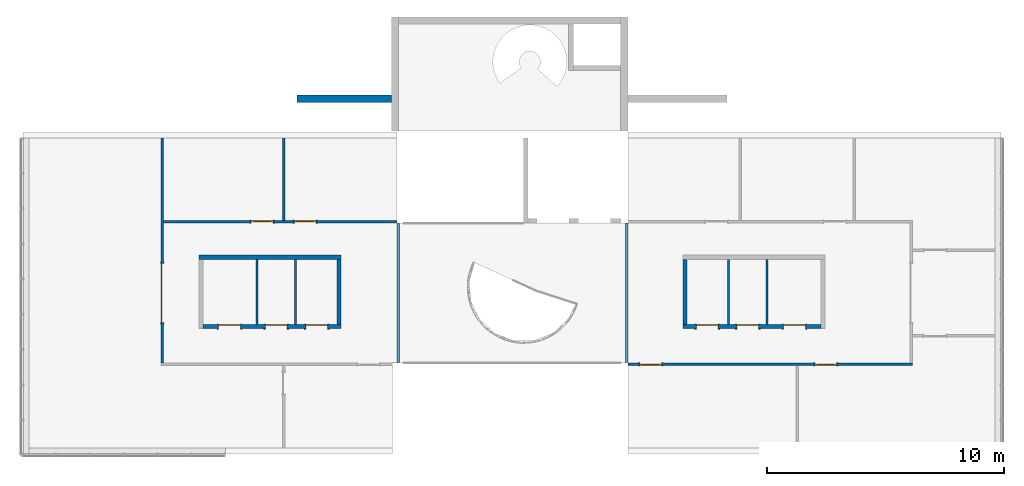
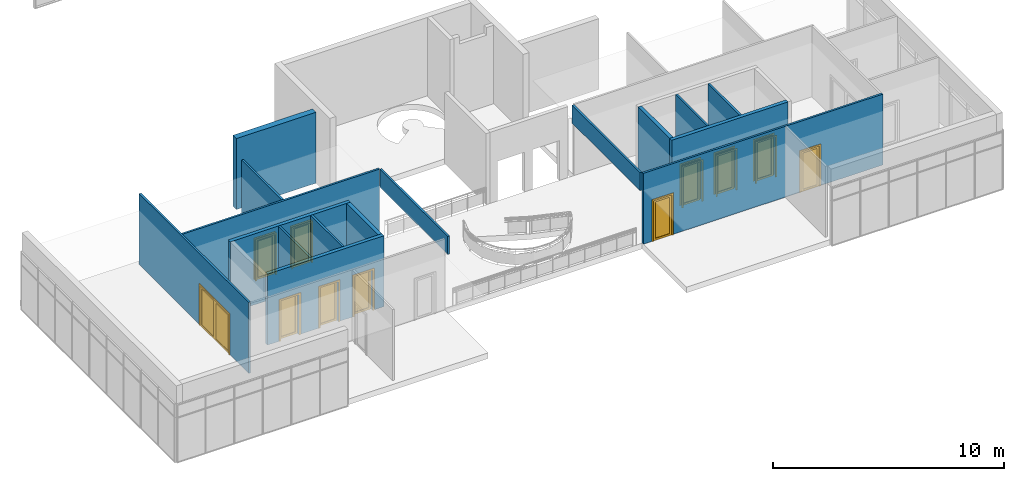
# One storey, part 8 of 11: 16 walls, 11 doors, 11 openings.
"""IFC2X3 building model written with IfcOpenShell, lengths in millimetres."""

from ifc_helpers import new_model, entity, si_unit, converted_unit, direction, frame, frame_2d, origin, origin_2d_with_axis, place, context, subcontext, project, spatial, polyline, rectangle, outline, extrude, source, transform, mapped, material, material_list, layer, layer_set, layer_usage, type_object, type_shapes, element, fill, save


model = new_model("IFC2X3")

# Units and contexts
model_context = context("Model", 3, precision=1e-06, world=origin(), true_north=direction((2.0, 6.12303176911189e-17, 1.0)))
context_of_model = context(None, 3, precision=1e-06, world=origin(), true_north=direction((2.0, 6.12303176911189e-17, 1.0)))
body_context = subcontext(model_context, "Body", "Model", "MODEL_VIEW")
ifc_project = project(units=[si_unit("LENGTHUNIT", "METRE", prefix="MILLI"), si_unit("AREAUNIT", "SQUARE_METRE", prefix="MILLI"), si_unit("VOLUMEUNIT", "CUBIC_METRE", prefix="MILLI"), converted_unit("PLANEANGLEUNIT", "DEGREE", entity("IfcRatioMeasure", 0.0174532925199433), si_unit("PLANEANGLEUNIT", "RADIAN"), dimensions=[0, 0, 0, 0, 0, 0, 0]), si_unit("TIMEUNIT", "SECOND")], contexts=[model_context, context_of_model])

# Site, building, storey
site_placement = place(None, origin())
site = spatial("IfcSite", under=ifc_project, at=site_placement, CompositionType="ELEMENT")
building_placement = place(site_placement, origin())
building = spatial("IfcBuilding", under=site, at=building_placement, CompositionType="ELEMENT")
storey_placement = place(building_placement, frame((0.0, 0.0, 3750.0)))
storey = spatial("IfcBuildingStorey", under=building, at=storey_placement, Name="02. 2 etg.", CompositionType="ELEMENT", Elevation=3750.00000000068)

# Wall, opening, door
ifc_material_1 = material(Name="Steel, Paint Finish, Ivory, Matte")
ifc_layer_1 = layer(ifc_material_1, 100.0)
ifc_layer_set_1 = layer_set([ifc_layer_1], Name="Basic Wall:_100mm")
ifc_layer_usage_1 = layer_usage(ifc_layer_set_1, "AXIS2", "NEGATIVE", 50.0)
wall_1_placement = place(storey_placement, frame((5679.11785617473, -9550.0, 0.0), z_axis=(0.0, 0.0, 1.0), x_axis=(0.0, 1.0, 0.0)))
wall_1 = element("IfcWallStandardCase", 1, at=wall_1_placement, inside=storey, material=ifc_layer_usage_1, Name="Basic Wall:_100mm", ObjectType="Basic Wall:_100mm", context=body_context, shape_type="SweptSolid", body=[
    extrude(rectangle(XDim=9490.00000000001, YDim=100.000000000001, at=frame_2d((4745.00000000001, 0.0), x_axis=(-1.0, 0.0))), origin(), (0.0, 0.0, 1.0), 3750.0),
])
opening_1_placement = place(wall_1_placement, frame((1700.0, -50.0, 0.0)))
opening_1 = element("IfcOpeningElement", 2, at=opening_1_placement, cuts=wall_1, Name="M_Double-Glass 1:2500x2100:2500x2100:1", ObjectType="Opening", context=body_context, shape_type="SweptSolid", body=[
    extrude(rectangle(XDim=2500.0, YDim=2100.0, at=frame_2d((1050.0, 1250.0), x_axis=(0.0, 1.0))), frame((0.0, 0.0, 0.0), z_axis=(0.0, 1.0, 0.0), x_axis=(0.0, 0.0, 1.0)), (0.0, 0.0, 1.0), 100.0),
])
ifc_material_2 = material(Name="Metal - Stainless Steel,Polished")
ifc_material_3 = material(Name="Glass")
ifc_material_4 = material(Name="Steel, Chrome Plated")
ifc_material_list_1 = material_list([ifc_material_2, ifc_material_3, ifc_material_4])
door_style_1 = type_object("IfcDoorStyle", Name="2500x2100", ConstructionType="NOTDEFINED", OperationType="DOUBLE_DOOR_SINGLE_SWING", ParameterTakesPrecedence=False, Sizeable=False)
shared_shape_1 = source(origin(), body_context, "Body", "SweptSolid", [
    extrude(outline(polyline([(-1326.0, -1069.0), (-1250.0, -1069.0), (-1250.0, 1031.0), (1250.0, 1031.0), (1250.0, -1069.0), (1326.0, -1069.0), (1326.0, 1107.0), (-1326.0, 1107.0), (-1326.0, -1069.0)])), frame((1250.0, -25.0, 1069.0), z_axis=(0.0, 1.0, 0.0), x_axis=(-1.0, 0.0, 0.0)), (0.0, 0.0, 1.0), 25.0),
    extrude(outline(polyline([(-1250.0, -1031.0), (-1250.0, 1069.0), (-1326.0, 1069.0), (-1326.0, -1107.0), (1326.0, -1107.0), (1326.0, 1069.0), (1250.0, 1069.0), (1250.0, -1031.0), (-1250.0, -1031.0)])), frame((1250.0, 100.0, 1069.0), z_axis=(0.0, -1.0, 0.0), x_axis=(-1.0, 0.0, 0.0)), (0.0, 0.0, -1.0), 24.999999999997),
    extrude(rectangle(XDim=7.14374999999973, YDim=1046.8, at=frame_2d((0.0, -5.6843418860808e-14), x_axis=(1.0, 0.0))), frame((1875.0, 78.1718749999958, 102.0), z_axis=(0.0, 0.0, 1.0), x_axis=(0.0, 1.0, 0.0)), (0.0, 0.0, 1.0), 1896.0),
    extrude(rectangle(XDim=7.14374999999973, YDim=1046.8, at=frame_2d((0.0, -5.6843418860808e-14), x_axis=(1.0, 0.0))), frame((625.0, 78.1718749999958, 102.0), z_axis=(0.0, 0.0, 1.0), x_axis=(0.0, 1.0, 0.0)), (0.0, 0.0, 1.0), 1896.0),
    extrude(outline(polyline([(-1050.0, -1250.0), (1050.0, -1250.0), (1050.0, 1250.0), (-1050.0, 1250.0), (-1050.0, -1250.0)]), holes=[polyline([(-948.0, 101.600000000038), (-948.0, 1148.40000000004), (948.0, 1148.40000000004), (948.0, 101.600000000038), (-948.0, 101.600000000038)]), polyline([(-948.0, -1148.39999999996), (-948.0, -101.599999999961), (948.0, -101.599999999961), (948.0, -1148.39999999996), (-948.0, -1148.39999999996)])]), frame((1250.0, 49.0, 1050.0), z_axis=(0.0, 1.0, 0.0), x_axis=(0.0, 0.0, -1.0)), (0.0, 0.0, 1.0), 51.0),
])
type_shapes(door_style_1, [shared_shape_1])
door_1_placement = place(opening_1_placement, origin())
door_1 = element("IfcDoor", 3, at=door_1_placement, inside=storey, type_object=door_style_1, material=ifc_material_list_1, Name="M_Double-Glass 1:2500x2100:2500x2100", ObjectType="2500x2100", OverallHeight=2100.0, OverallWidth=2500.0, context=body_context, shape_type="MappedRepresentation", body=[
    mapped(shared_shape_1, transform((0.0, 0.0, 0.0), scale=1.0)),
])
fill(opening_1, door_1)

# Wall, openings, doors
ifc_layer_usage_2 = layer_usage(ifc_layer_set_1, "AXIS2", "NEGATIVE", 50.0)
wall_2_placement = place(storey_placement, frame((15590.0, -3600.0, 0.0), z_axis=(0.0, 0.0, 1.0), x_axis=(-1.0, 0.0, 0.0)))
wall_2 = element("IfcWallStandardCase", 4, at=wall_2_placement, inside=storey, material=ifc_layer_usage_2, Name="Basic Wall:_100mm", ObjectType="Basic Wall:_100mm", context=body_context, shape_type="SweptSolid", body=[
    extrude(rectangle(XDim=9860.88214382529, YDim=100.0, at=frame_2d((4930.44107191265, 3.5527136788005e-14), x_axis=(-1.0, 0.0))), origin(), (0.0, 0.0, 1.0), 3750.0),
])
opening_2_placement = place(wall_2_placement, frame((6155.0, 50.0, 0.0)))
opening_2 = element("IfcOpeningElement", 5, at=opening_2_placement, cuts=wall_2, Name="M_Single-Glass 1:0915 x 2134mm:0915 x 2134mm:1", ObjectType="Opening", context=body_context, shape_type="SweptSolid", body=[
    extrude(rectangle(XDim=914.999999999999, YDim=2134.0, at=frame_2d((1067.0, 457.5), x_axis=(0.0, 1.0))), frame((0.0, 0.0, 0.0), z_axis=(0.0, -1.0, 0.0), x_axis=(0.0, 0.0, 1.0)), (0.0, 0.0, 1.0), 100.0),
])
opening_3_placement = place(wall_2_placement, frame((4340.0, 50.0, 0.0)))
opening_3 = element("IfcOpeningElement", 6, at=opening_3_placement, cuts=wall_2, Name="M_Single-Glass 1:0915 x 2134mm:0915 x 2134mm:1", ObjectType="Opening", context=body_context, shape_type="SweptSolid", body=[
    extrude(rectangle(XDim=914.999999999999, YDim=2134.0, at=frame_2d((1067.0, 457.5), x_axis=(0.0, -1.0))), frame((0.0, 0.0, 0.0), z_axis=(0.0, -1.0, 0.0), x_axis=(0.0, 0.0, 1.0)), (0.0, 0.0, 1.0), 100.0),
])
ifc_material_5 = material(Name="Stainless Steel")
ifc_material_list_2 = material_list([ifc_material_5, ifc_material_3])
door_style_2 = type_object("IfcDoorStyle", Name="0915 x 2134mm", ConstructionType="NOTDEFINED", OperationType="SINGLE_SWING_RIGHT", ParameterTakesPrecedence=False, Sizeable=False)
shared_shape_2 = source(origin(), body_context, "Body", "SweptSolid", [
    extrude(outline(polyline([(-457.500000000003, -1048.0), (-457.500000000003, 1086.0), (-533.499999999999, 1086.0), (-533.499999999999, -1124.0), (533.500000000001, -1124.0), (533.500000000001, 1086.0), (457.500000000001, 1086.0), (457.500000000001, -1048.0), (-457.500000000003, -1048.0)])), frame((457.500000000001, -25.0, 1086.0), z_axis=(0.0, -1.0, 0.0), x_axis=(-1.0, 0.0, 0.0)), (0.0, 0.0, -1.0), 25.0),
    extrude(outline(polyline([(-457.500000000001, -1048.0), (-457.500000000001, 1086.0), (-533.499999999997, 1086.0), (-533.499999999997, -1124.0), (533.499999999999, -1124.0), (533.499999999999, 1086.0), (457.499999999999, 1086.0), (457.499999999999, -1048.0), (-457.500000000001, -1048.0)])), frame((457.499999999999, 100.0, 1086.0), z_axis=(0.0, -1.0, 0.0), x_axis=(-1.0, 0.0, 0.0)), (0.0, 0.0, -1.0), 25.0000000000156),
    extrude(rectangle(XDim=6.35, YDim=711.0, at=frame_2d((-4.21884749357559e-15, 0.0), x_axis=(1.0, 0.0))), frame((457.5, 74.6000000000039, 102.0), z_axis=(0.0, 0.0, 1.0), x_axis=(0.0, 1.0, 0.0)), (0.0, 0.0, 1.0), 1930.0),
    extrude(outline(polyline([(-1067.0, -457.499999999998), (1067.0, -457.499999999998), (1067.0, 457.499999999998), (-1067.0, 457.499999999998), (-1067.0, -457.499999999998)]), holes=[polyline([(-965.0, 355.499999999998), (965.0, 355.499999999998), (965.0, -355.500000000002), (-965.0, -355.500000000002), (-965.0, 355.499999999998)])]), frame((457.499999999998, 49.0, 1067.0), z_axis=(0.0, 1.0, 0.0), x_axis=(0.0, 0.0, -1.0)), (0.0, 0.0, 1.0), 51.0),
])
type_shapes(door_style_2, [shared_shape_2])
door_2_placement = place(opening_2_placement, frame((0.0, 0.0, 0.0), z_axis=(0.0, 0.0, 1.0), x_axis=(-1.0, 0.0, 0.0)))
door_2 = element("IfcDoor", 7, at=door_2_placement, inside=storey, type_object=door_style_2, material=ifc_material_list_2, Name="M_Single-Glass 1:0915 x 2134mm:0915 x 2134mm", ObjectType="0915 x 2134mm", OverallHeight=2134.0, OverallWidth=915.0, context=body_context, shape_type="MappedRepresentation", body=[
    mapped(shared_shape_2, transform((0.0, 0.0, 0.0), scale=1.0)),
])
fill(opening_2, door_2)
ifc_material_list_3 = material_list([ifc_material_5, ifc_material_3])
door_style_3 = type_object("IfcDoorStyle", Name="0915 x 2134mm", ConstructionType="NOTDEFINED", OperationType="SINGLE_SWING_LEFT", ParameterTakesPrecedence=False, Sizeable=False)
shared_shape_3 = source(origin(), body_context, "Body", "SweptSolid", [
    extrude(outline(polyline([(-457.500000000003, -1048.0), (-457.500000000003, 1086.0), (-533.499999999999, 1086.0), (-533.499999999999, -1124.0), (533.500000000001, -1124.0), (533.500000000001, 1086.0), (457.500000000001, 1086.0), (457.500000000001, -1048.0), (-457.500000000003, -1048.0)])), frame((457.499999999999, 0.0, 1086.0), z_axis=(0.0, 1.0, 0.0), x_axis=(1.0, 0.0, 0.0)), (0.0, 0.0, -1.0), 25.0),
    extrude(outline(polyline([(-457.500000000001, -1048.0), (-457.500000000001, 1086.0), (-533.499999999997, 1086.0), (-533.499999999997, -1124.0), (533.499999999999, -1124.0), (533.499999999999, 1086.0), (457.499999999999, 1086.0), (457.499999999999, -1048.0), (-457.500000000001, -1048.0)])), frame((457.500000000001, 125.0, 1086.0), z_axis=(0.0, 1.0, 0.0), x_axis=(1.0, 0.0, 0.0)), (0.0, 0.0, -1.0), 25.0000000000156),
    extrude(rectangle(XDim=711.0, YDim=6.35, at=origin_2d_with_axis()), frame((457.5, 74.6000000000257, 102.0)), (0.0, 0.0, 1.0), 1930.0),
    extrude(outline(polyline([(-1067.0, -457.499999999998), (1067.0, -457.499999999998), (1067.0, 457.499999999998), (-1067.0, 457.499999999998), (-1067.0, -457.499999999998)]), holes=[polyline([(-965.0, 355.499999999998), (965.0, 355.499999999998), (965.0, -355.500000000002), (-965.0, -355.500000000002), (-965.0, 355.499999999998)])]), frame((457.500000000002, 100.0, 1067.0), z_axis=(0.0, -1.0, 0.0), x_axis=(0.0, 0.0, -1.0)), (0.0, 0.0, 1.0), 51.0),
])
type_shapes(door_style_3, [shared_shape_3])
door_3_placement = place(opening_3_placement, frame((0.0, 0.0, 0.0), z_axis=(0.0, 0.0, 1.0), x_axis=(-1.0, 0.0, 0.0)))
door_3 = element("IfcDoor", 8, at=door_3_placement, inside=storey, type_object=door_style_3, material=ifc_material_list_3, Name="M_Single-Glass 1:0915 x 2134mm:0915 x 2134mm", ObjectType="0915 x 2134mm", OverallHeight=2134.0, OverallWidth=915.0, context=body_context, shape_type="MappedRepresentation", body=[
    mapped(shared_shape_3, transform((0.0, 0.0, 0.0), scale=1.0)),
])
fill(opening_3, door_3)

# Walls
ifc_layer_usage_3 = layer_usage(ifc_layer_set_1, "AXIS2", "NEGATIVE", 50.0)
wall_3_placement = place(storey_placement, frame((10800.0, -3550.0, 0.0), z_axis=(0.0, 0.0, 1.0), x_axis=(0.0, 1.0, 0.0)))
element("IfcWallStandardCase", 9, at=wall_3_placement, inside=storey, material=ifc_layer_usage_3, Name="Basic Wall:_100mm", ObjectType="Basic Wall:_100mm", context=body_context, shape_type="SweptSolid", body=[
    extrude(rectangle(XDim=3490.00000000001, YDim=99.9999999999989, at=frame_2d((1745.00000000001, 0.0), x_axis=(-1.0, 0.0))), origin(), (0.0, 0.0, 1.0), 3750.0),
])
ifc_layer_2 = layer(ifc_material_1, 180.0)
ifc_layer_set_2 = layer_set([ifc_layer_2], Name="Basic Wall:_180mm")
ifc_layer_usage_4 = layer_usage(ifc_layer_set_2, "AXIS2", "NEGATIVE", 90.0)
wall_4_placement = place(storey_placement, frame((7229.11785617473, -5096.65631369453, 0.0)))
element("IfcWallStandardCase", 10, at=wall_4_placement, inside=storey, material=ifc_layer_usage_4, Name="Basic Wall:_180mm", ObjectType="Basic Wall:_180mm", context=body_context, shape_type="SweptSolid", body=[
    extrude(rectangle(XDim=6000.0, YDim=180.0, at=frame_2d((3000.0, 0.0), x_axis=(-1.0, 0.0))), origin(), (0.0, 0.0, 1.0), 3750.0),
])

# Wall, openings, doors
ifc_layer_usage_5 = layer_usage(ifc_layer_set_2, "AXIS2", "NEGATIVE", 90.0)
wall_5_placement = place(storey_placement, frame((13229.1178561747, -8016.65631369453, 0.0), z_axis=(0.0, 0.0, 1.0), x_axis=(-1.0, 0.0, 0.0)))
wall_5 = element("IfcWallStandardCase", 11, at=wall_5_placement, inside=storey, material=ifc_layer_usage_5, Name="Basic Wall:_180mm", ObjectType="Basic Wall:_180mm", context=body_context, shape_type="SweptSolid", body=[
    extrude(rectangle(XDim=5820.0, YDim=180.0, at=frame_2d((2910.0, 0.0), x_axis=(-1.0, 0.0))), origin(), (0.0, 0.0, 1.0), 3750.0),
])
opening_4_placement = place(wall_5_placement, frame((5167.5, 90.0, 0.0)))
opening_4 = element("IfcOpeningElement", 12, at=opening_4_placement, cuts=wall_5, Name="M_Single-Glass 1:0915 x 2134mm:0915 x 2134mm:1", ObjectType="Opening", context=body_context, shape_type="SweptSolid", body=[
    extrude(rectangle(XDim=914.999999999999, YDim=2134.0, at=frame_2d((1067.0, 457.499999999999), x_axis=(0.0, -1.0))), frame((0.0, 0.0, 0.0), z_axis=(0.0, -1.0, 0.0), x_axis=(0.0, 0.0, 1.0)), (0.0, 0.0, 1.0), 180.0),
])
opening_5_placement = place(wall_5_placement, frame((3196.5, 90.0, 0.0)))
opening_5 = element("IfcOpeningElement", 13, at=opening_5_placement, cuts=wall_5, Name="M_Single-Glass 1:0915 x 2134mm:0915 x 2134mm:1", ObjectType="Opening", context=body_context, shape_type="SweptSolid", body=[
    extrude(rectangle(XDim=914.999999999999, YDim=2134.0, at=frame_2d((1067.0, 457.5), x_axis=(0.0, -1.0))), frame((0.0, 0.0, 0.0), z_axis=(0.0, -1.0, 0.0), x_axis=(0.0, 0.0, 1.0)), (0.0, 0.0, 1.0), 180.0),
])
opening_6_placement = place(wall_5_placement, frame((1486.5, 90.0, 0.0)))
opening_6 = element("IfcOpeningElement", 14, at=opening_6_placement, cuts=wall_5, Name="M_Single-Glass 1:0915 x 2134mm:0915 x 2134mm:1", ObjectType="Opening", context=body_context, shape_type="SweptSolid", body=[
    extrude(rectangle(XDim=914.999999999999, YDim=2134.0, at=frame_2d((1067.0, 457.5), x_axis=(0.0, -1.0))), frame((0.0, 0.0, 0.0), z_axis=(0.0, -1.0, 0.0), x_axis=(0.0, 0.0, 1.0)), (0.0, 0.0, 1.0), 180.0),
])
ifc_material_list_4 = material_list([ifc_material_5, ifc_material_3])
door_style_4 = type_object("IfcDoorStyle", Name="0915 x 2134mm", ConstructionType="NOTDEFINED", OperationType="SINGLE_SWING_LEFT", ParameterTakesPrecedence=False, Sizeable=False)
shared_shape_4 = source(origin(), body_context, "Body", "SweptSolid", [
    extrude(outline(polyline([(-457.500000000003, -1048.0), (-457.500000000003, 1086.0), (-533.499999999999, 1086.0), (-533.499999999999, -1124.0), (533.500000000001, -1124.0), (533.500000000001, 1086.0), (457.500000000001, 1086.0), (457.500000000001, -1048.0), (-457.500000000003, -1048.0)])), frame((457.499999999999, 0.0, 1086.0), z_axis=(0.0, 1.0, 0.0), x_axis=(1.0, 0.0, 0.0)), (0.0, 0.0, -1.0), 25.0),
    extrude(outline(polyline([(-457.500000000001, -1048.0), (-457.500000000001, 1086.0), (-533.499999999997, 1086.0), (-533.499999999997, -1124.0), (533.499999999999, -1124.0), (533.499999999999, 1086.0), (457.499999999999, 1086.0), (457.499999999999, -1048.0), (-457.500000000001, -1048.0)])), frame((457.500000000001, 205.0, 1086.0), z_axis=(0.0, 1.0, 0.0), x_axis=(1.0, 0.0, 0.0)), (0.0, 0.0, -1.0), 25.0000000000156),
    extrude(rectangle(XDim=711.0, YDim=6.35, at=frame_2d((0.0, 4.21884749357559e-15), x_axis=(1.0, 0.0))), frame((457.5, 154.600000000026, 102.0)), (0.0, 0.0, 1.0), 1930.0),
    extrude(outline(polyline([(-1067.0, -457.499999999998), (1067.0, -457.499999999998), (1067.0, 457.499999999998), (-1067.0, 457.499999999998), (-1067.0, -457.499999999998)]), holes=[polyline([(-965.0, 355.499999999998), (965.0, 355.499999999998), (965.0, -355.500000000002), (-965.0, -355.500000000002), (-965.0, 355.499999999998)])]), frame((457.500000000002, 180.0, 1067.0), z_axis=(0.0, -1.0, 0.0), x_axis=(0.0, 0.0, -1.0)), (0.0, 0.0, 1.0), 51.0),
])
type_shapes(door_style_4, [shared_shape_4])
door_4_placement = place(opening_4_placement, frame((0.0, 0.0, 0.0), z_axis=(0.0, 0.0, 1.0), x_axis=(-1.0, 0.0, 0.0)))
door_4 = element("IfcDoor", 15, at=door_4_placement, inside=storey, type_object=door_style_4, material=ifc_material_list_4, Name="M_Single-Glass 1:0915 x 2134mm:0915 x 2134mm", ObjectType="0915 x 2134mm", OverallHeight=2134.0, OverallWidth=914.999999999999, context=body_context, shape_type="MappedRepresentation", body=[
    mapped(shared_shape_4, transform((0.0, 0.0, 0.0), scale=1.0)),
])
fill(opening_4, door_4)
ifc_material_list_5 = material_list([ifc_material_5, ifc_material_3])
door_5_placement = place(opening_5_placement, frame((0.0, 0.0, 0.0), z_axis=(0.0, 0.0, 1.0), x_axis=(-1.0, 0.0, 0.0)))
door_5 = element("IfcDoor", 16, at=door_5_placement, inside=storey, type_object=door_style_4, material=ifc_material_list_5, Name="M_Single-Glass 1:0915 x 2134mm:0915 x 2134mm", ObjectType="0915 x 2134mm", OverallHeight=2134.0, OverallWidth=915.0, context=body_context, shape_type="MappedRepresentation", body=[
    mapped(shared_shape_4, transform((0.0, 0.0, 0.0), scale=1.0)),
])
fill(opening_5, door_5)
ifc_material_list_6 = material_list([ifc_material_5, ifc_material_3])
door_6_placement = place(opening_6_placement, frame((0.0, 0.0, 0.0), z_axis=(0.0, 0.0, 1.0), x_axis=(-1.0, 0.0, 0.0)))
door_6 = element("IfcDoor", 17, at=door_6_placement, inside=storey, type_object=door_style_4, material=ifc_material_list_6, Name="M_Single-Glass 1:0915 x 2134mm:0915 x 2134mm", ObjectType="0915 x 2134mm", OverallHeight=2134.0, OverallWidth=915.0, context=body_context, shape_type="MappedRepresentation", body=[
    mapped(shared_shape_4, transform((0.0, 0.0, 0.0), scale=1.0)),
])
fill(opening_6, door_6)

# Walls
ifc_layer_usage_6 = layer_usage(ifc_layer_set_2, "AXIS2", "NEGATIVE", 90.0)
wall_6_placement = place(storey_placement, frame((13139.1178561747, -5186.65631369453, 0.0), z_axis=(0.0, 0.0, 1.0), x_axis=(0.0, -1.0, 0.0)))
element("IfcWallStandardCase", 18, at=wall_6_placement, inside=storey, material=ifc_layer_usage_6, Name="Basic Wall:_180mm", ObjectType="Basic Wall:_180mm", context=body_context, shape_type="SweptSolid", body=[
    extrude(rectangle(XDim=2740.0, YDim=179.999999999998, at=frame_2d((1370.0, 0.0), x_axis=(-1.0, 0.0))), origin(), (0.0, 0.0, 1.0), 3750.0),
])
ifc_layer_usage_7 = layer_usage(ifc_layer_set_1, "AXIS2", "POSITIVE", -50.0)
wall_7_placement = place(storey_placement, frame((9679.11785617473, -5186.65631369453, 0.0), z_axis=(0.0, 0.0, 1.0), x_axis=(0.0, -1.0, 0.0)))
element("IfcWallStandardCase", 19, at=wall_7_placement, inside=storey, material=ifc_layer_usage_7, Name="Basic Wall:_100mm", ObjectType="Basic Wall:_100mm", context=body_context, shape_type="SweptSolid", body=[
    extrude(rectangle(XDim=2740.0, YDim=99.9999999999989, at=frame_2d((1370.0, 0.0), x_axis=(-1.0, 0.0))), origin(), (0.0, 0.0, 1.0), 3750.0),
])
ifc_layer_usage_8 = layer_usage(ifc_layer_set_1, "AXIS2", "NEGATIVE", 50.0)
wall_8_placement = place(storey_placement, frame((11301.1178561747, -5186.65631369453, 0.0), z_axis=(0.0, 0.0, 1.0), x_axis=(0.0, -1.0, 0.0)))
element("IfcWallStandardCase", 20, at=wall_8_placement, inside=storey, material=ifc_layer_usage_8, Name="Basic Wall:_100mm", ObjectType="Basic Wall:_100mm", context=body_context, shape_type="SweptSolid", body=[
    extrude(rectangle(XDim=2740.0, YDim=99.9999999999989, at=frame_2d((1370.0, 0.0), x_axis=(-1.0, 0.0))), origin(), (0.0, 0.0, 1.0), 3750.0),
])

# Wall, openings, doors
ifc_layer_usage_9 = layer_usage(ifc_layer_set_1, "AXIS2", "POSITIVE", -50.0)
wall_9_placement = place(storey_placement, frame((25318.2357123495, -9600.0, 0.0)))
wall_9 = element("IfcWallStandardCase", 21, at=wall_9_placement, inside=storey, material=ifc_layer_usage_9, Name="Basic Wall:_100mm", ObjectType="Basic Wall:_100mm", context=body_context, shape_type="SweptSolid", body=[
    extrude(rectangle(XDim=11990.0, YDim=99.9999999999989, at=frame_2d((5995.0, -1.59872115546023e-13), x_axis=(-1.0, 0.0))), origin(), (0.0, 0.0, 1.0), 3750.0),
])
opening_7_placement = place(wall_9_placement, frame((8797.5, 50.0, 0.0)))
opening_7 = element("IfcOpeningElement", 22, at=opening_7_placement, cuts=wall_9, Name="M_Single-Glass 1:0915 x 2134mm:0915 x 2134mm:1", ObjectType="Opening", context=body_context, shape_type="SweptSolid", body=[
    extrude(rectangle(XDim=914.999999999999, YDim=2134.0, at=frame_2d((1067.0, 457.5), x_axis=(0.0, 1.0))), frame((0.0, 0.0, 0.0), z_axis=(0.0, -1.0, 0.0), x_axis=(0.0, 0.0, 1.0)), (0.0, 0.0, 1.0), 100.0),
])
opening_8_placement = place(wall_9_placement, frame((1415.0, 50.0, 0.0)))
opening_8 = element("IfcOpeningElement", 23, at=opening_8_placement, cuts=wall_9, Name="M_Single-Glass 1:0915 x 2134mm:0915 x 2134mm:1", ObjectType="Opening", context=body_context, shape_type="SweptSolid", body=[
    extrude(rectangle(XDim=914.999999999999, YDim=2134.0, at=frame_2d((1067.0, 457.5), x_axis=(0.0, 1.0))), frame((0.0, 0.0, 0.0), z_axis=(0.0, -1.0, 0.0), x_axis=(0.0, 0.0, 1.0)), (0.0, 0.0, 1.0), 100.0),
])
ifc_material_list_7 = material_list([ifc_material_5, ifc_material_3])
door_7_placement = place(opening_7_placement, frame((0.0, 0.0, 0.0), z_axis=(0.0, 0.0, 1.0), x_axis=(-1.0, 0.0, 0.0)))
door_7 = element("IfcDoor", 24, at=door_7_placement, inside=storey, type_object=door_style_2, material=ifc_material_list_7, Name="M_Single-Glass 1:0915 x 2134mm:0915 x 2134mm", ObjectType="0915 x 2134mm", OverallHeight=2134.0, OverallWidth=915.0, context=body_context, shape_type="MappedRepresentation", body=[
    mapped(shared_shape_2, transform((0.0, 0.0, 0.0), scale=1.0)),
])
fill(opening_7, door_7)
ifc_material_list_8 = material_list([ifc_material_5, ifc_material_3])
door_8_placement = place(opening_8_placement, frame((0.0, 0.0, 0.0), z_axis=(0.0, 0.0, 1.0), x_axis=(-1.0, 0.0, 0.0)))
door_8 = element("IfcDoor", 25, at=door_8_placement, inside=storey, type_object=door_style_2, material=ifc_material_list_8, Name="M_Single-Glass 1:0915 x 2134mm:0915 x 2134mm", ObjectType="0915 x 2134mm", OverallHeight=2134.0, OverallWidth=915.0, context=body_context, shape_type="MappedRepresentation", body=[
    mapped(shared_shape_2, transform((0.0, 0.0, 0.0), scale=1.0)),
])
fill(opening_8, door_8)

ifc_layer_usage_10 = layer_usage(ifc_layer_set_2, "AXIS2", "POSITIVE", -90.0)
wall_10_placement = place(storey_placement, frame((27629.1178561747, -8016.65631369453, 0.0)))
wall_10 = element("IfcWallStandardCase", 26, at=wall_10_placement, inside=storey, material=ifc_layer_usage_10, Name="Basic Wall:_180mm", ObjectType="Basic Wall:_180mm", context=body_context, shape_type="SweptSolid", body=[
    extrude(rectangle(XDim=5819.99999999999, YDim=180.0, at=frame_2d((2910.0, 0.0), x_axis=(-1.0, 0.0))), origin(), (0.0, 0.0, 1.0), 3750.0),
])
opening_9_placement = place(wall_10_placement, frame((571.5, -90.0, 0.0)))
opening_9 = element("IfcOpeningElement", 27, at=opening_9_placement, cuts=wall_10, Name="M_Single-Glass 1:0915 x 2134mm:0915 x 2134mm:1", ObjectType="Opening", context=body_context, shape_type="SweptSolid", body=[
    extrude(rectangle(XDim=914.999999999999, YDim=2134.0, at=frame_2d((1067.0, 457.5), x_axis=(0.0, 1.0))), frame((0.0, 0.0, 0.0), z_axis=(0.0, 1.0, 0.0), x_axis=(0.0, 0.0, 1.0)), (0.0, 0.0, 1.0), 180.0),
])
opening_10_placement = place(wall_10_placement, frame((2281.5, -90.0, 0.0)))
opening_10 = element("IfcOpeningElement", 28, at=opening_10_placement, cuts=wall_10, Name="M_Single-Glass 1:0915 x 2134mm:0915 x 2134mm:1", ObjectType="Opening", context=body_context, shape_type="SweptSolid", body=[
    extrude(rectangle(XDim=914.999999999999, YDim=2134.0, at=frame_2d((1067.0, 457.5), x_axis=(0.0, 1.0))), frame((0.0, 0.0, 0.0), z_axis=(0.0, 1.0, 0.0), x_axis=(0.0, 0.0, 1.0)), (0.0, 0.0, 1.0), 180.0),
])
opening_11_placement = place(wall_10_placement, frame((4252.49999999999, -90.0, 0.0)))
opening_11 = element("IfcOpeningElement", 29, at=opening_11_placement, cuts=wall_10, Name="M_Single-Glass 1:0915 x 2134mm:0915 x 2134mm:1", ObjectType="Opening", context=body_context, shape_type="SweptSolid", body=[
    extrude(rectangle(XDim=914.999999999999, YDim=2134.0, at=frame_2d((1067.0, 457.5), x_axis=(0.0, 1.0))), frame((0.0, 0.0, 0.0), z_axis=(0.0, 1.0, 0.0), x_axis=(0.0, 0.0, 1.0)), (0.0, 0.0, 1.0), 180.0),
])
ifc_material_list_9 = material_list([ifc_material_5, ifc_material_3])
door_style_5 = type_object("IfcDoorStyle", Name="0915 x 2134mm", ConstructionType="NOTDEFINED", OperationType="SINGLE_SWING_RIGHT", ParameterTakesPrecedence=False, Sizeable=False)
shared_shape_5 = source(origin(), body_context, "Body", "SweptSolid", [
    extrude(outline(polyline([(-457.500000000003, -1048.0), (-457.500000000003, 1086.0), (-533.499999999999, 1086.0), (-533.499999999999, -1124.0), (533.500000000001, -1124.0), (533.500000000001, 1086.0), (457.500000000001, 1086.0), (457.500000000001, -1048.0), (-457.500000000003, -1048.0)])), frame((457.500000000001, -25.0, 1086.0), z_axis=(0.0, -1.0, 0.0), x_axis=(-1.0, 0.0, 0.0)), (0.0, 0.0, -1.0), 25.0),
    extrude(outline(polyline([(-457.500000000001, -1048.0), (-457.500000000001, 1086.0), (-533.499999999997, 1086.0), (-533.499999999997, -1124.0), (533.499999999999, -1124.0), (533.499999999999, 1086.0), (457.499999999999, 1086.0), (457.499999999999, -1048.0), (-457.500000000001, -1048.0)])), frame((457.499999999999, 180.0, 1086.0), z_axis=(0.0, -1.0, 0.0), x_axis=(-1.0, 0.0, 0.0)), (0.0, 0.0, -1.0), 25.0000000000156),
    extrude(rectangle(XDim=6.35, YDim=711.0, at=frame_2d((-4.21884749357559e-15, 0.0), x_axis=(1.0, 0.0))), frame((457.5, 154.600000000001, 102.0), z_axis=(0.0, 0.0, 1.0), x_axis=(0.0, 1.0, 0.0)), (0.0, 0.0, 1.0), 1930.0),
    extrude(outline(polyline([(-1067.0, -457.499999999998), (1067.0, -457.499999999998), (1067.0, 457.499999999998), (-1067.0, 457.499999999998), (-1067.0, -457.499999999998)]), holes=[polyline([(-965.0, 355.499999999998), (965.0, 355.499999999998), (965.0, -355.500000000002), (-965.0, -355.500000000002), (-965.0, 355.499999999998)])]), frame((457.499999999998, 129.0, 1067.0), z_axis=(0.0, 1.0, 0.0), x_axis=(0.0, 0.0, -1.0)), (0.0, 0.0, 1.0), 51.0),
])
type_shapes(door_style_5, [shared_shape_5])
door_9_placement = place(opening_9_placement, origin())
door_9 = element("IfcDoor", 30, at=door_9_placement, inside=storey, type_object=door_style_5, material=ifc_material_list_9, Name="M_Single-Glass 1:0915 x 2134mm:0915 x 2134mm", ObjectType="0915 x 2134mm", OverallHeight=2134.0, OverallWidth=915.0, context=body_context, shape_type="MappedRepresentation", body=[
    mapped(shared_shape_5, transform((0.0, 0.0, 0.0), scale=1.0)),
])
fill(opening_9, door_9)
ifc_material_list_10 = material_list([ifc_material_5, ifc_material_3])
door_10_placement = place(opening_10_placement, origin())
door_10 = element("IfcDoor", 31, at=door_10_placement, inside=storey, type_object=door_style_5, material=ifc_material_list_10, Name="M_Single-Glass 1:0915 x 2134mm:0915 x 2134mm", ObjectType="0915 x 2134mm", OverallHeight=2134.0, OverallWidth=915.0, context=body_context, shape_type="MappedRepresentation", body=[
    mapped(shared_shape_5, transform((0.0, 0.0, 0.0), scale=1.0)),
])
fill(opening_10, door_10)
ifc_material_list_11 = material_list([ifc_material_5, ifc_material_3])
door_11_placement = place(opening_11_placement, origin())
door_11 = element("IfcDoor", 32, at=door_11_placement, inside=storey, type_object=door_style_5, material=ifc_material_list_11, Name="M_Single-Glass 1:0915 x 2134mm:0915 x 2134mm", ObjectType="0915 x 2134mm", OverallHeight=2134.0, OverallWidth=915.0, context=body_context, shape_type="MappedRepresentation", body=[
    mapped(shared_shape_5, transform((0.0, 0.0, 0.0), scale=1.0)),
])
fill(opening_11, door_11)

# Walls
ifc_layer_usage_11 = layer_usage(ifc_layer_set_2, "AXIS2", "POSITIVE", -90.0)
wall_11_placement = place(storey_placement, frame((27719.1178561747, -5186.65631369453, 0.0), z_axis=(0.0, 0.0, 1.0), x_axis=(0.0, -1.0, 0.0)))
element("IfcWallStandardCase", 33, at=wall_11_placement, inside=storey, material=ifc_layer_usage_11, Name="Basic Wall:_180mm", ObjectType="Basic Wall:_180mm", context=body_context, shape_type="SweptSolid", body=[
    extrude(rectangle(XDim=2740.0, YDim=180.000000000002, at=frame_2d((1370.0, 0.0), x_axis=(-1.0, 0.0))), origin(), (0.0, 0.0, 1.0), 3750.0),
])
ifc_layer_usage_12 = layer_usage(ifc_layer_set_1, "AXIS2", "NEGATIVE", 50.0)
wall_12_placement = place(storey_placement, frame((31179.1178561747, -5186.65631369453, 0.0), z_axis=(0.0, 0.0, 1.0), x_axis=(0.0, -1.0, 0.0)))
element("IfcWallStandardCase", 34, at=wall_12_placement, inside=storey, material=ifc_layer_usage_12, Name="Basic Wall:_100mm", ObjectType="Basic Wall:_100mm", context=body_context, shape_type="SweptSolid", body=[
    extrude(rectangle(XDim=2740.0, YDim=100.000000000003, at=frame_2d((1370.0, 0.0), x_axis=(-1.0, 0.0))), origin(), (0.0, 0.0, 1.0), 3750.0),
])
ifc_layer_usage_13 = layer_usage(ifc_layer_set_1, "AXIS2", "POSITIVE", -50.0)
wall_13_placement = place(storey_placement, frame((29557.1178561747, -5186.65631369453, 0.0), z_axis=(0.0, 0.0, 1.0), x_axis=(0.0, -1.0, 0.0)))
element("IfcWallStandardCase", 35, at=wall_13_placement, inside=storey, material=ifc_layer_usage_13, Name="Basic Wall:_100mm", ObjectType="Basic Wall:_100mm", context=body_context, shape_type="SweptSolid", body=[
    extrude(rectangle(XDim=2740.0, YDim=100.000000000003, at=frame_2d((1370.0, 0.0), x_axis=(-1.0, 0.0))), origin(), (0.0, 0.0, 1.0), 3750.0),
])
ifc_layer_usage_14 = layer_usage(ifc_layer_set_1, "AXIS2", "NEGATIVE", 50.0)
wall_14_placement = place(storey_placement, frame((15640.0, -3660.0, 2800.0), z_axis=(0.0, 0.0, 1.0), x_axis=(0.0, -1.0, 0.0)))
element("IfcWallStandardCase", 36, at=wall_14_placement, inside=storey, material=ifc_layer_usage_14, Name="Basic Wall:_100mm", ObjectType="Basic Wall:_100mm", context=body_context, shape_type="SweptSolid", body=[
    extrude(rectangle(XDim=5879.99999999997, YDim=99.9999999999989, at=frame_2d((2939.99999999998, 2.1316282072803e-14), x_axis=(-1.0, 0.0))), origin(), (0.0, 0.0, 1.0), 949.999999999925),
])
ifc_layer_usage_15 = layer_usage(ifc_layer_set_1, "AXIS2", "NEGATIVE", 50.0)
wall_15_placement = place(storey_placement, frame((25268.2357123494, -3650.0, 2800.0), z_axis=(0.0, 0.0, 1.0), x_axis=(0.0, -1.0, 0.0)))
element("IfcWallStandardCase", 37, at=wall_15_placement, inside=storey, material=ifc_layer_usage_15, Name="Basic Wall:_100mm", ObjectType="Basic Wall:_100mm", context=body_context, shape_type="SweptSolid", body=[
    extrude(rectangle(XDim=5890.0, YDim=100.000000000003, at=frame_2d((2945.0, -7.105427357601e-15), x_axis=(-1.0, 0.0))), origin(), (0.0, 0.0, 1.0), 950.000000000001),
])
ifc_material_6 = material(Name="Brick, Engineering, Soldier Course")
ifc_layer_3 = layer(ifc_material_6, 300.0)
ifc_layer_set_3 = layer_set([ifc_layer_3], Name="Basic Wall:Generic - 300mm")
ifc_layer_usage_16 = layer_usage(ifc_layer_set_3, "AXIS2", "NEGATIVE", 150.0)
wall_16_placement = place(storey_placement, frame((15344.0, 1590.0, 0.0), z_axis=(0.0, 0.0, 1.0), x_axis=(-1.0, 0.0, 0.0)))
element("IfcWallStandardCase", 38, at=wall_16_placement, inside=storey, material=ifc_layer_usage_16, Name="Basic Wall:Generic - 300mm", ObjectType="Basic Wall:Generic - 300mm:6291", context=body_context, shape_type="SweptSolid", body=[
    extrude(rectangle(XDim=3984.88214382528, YDim=300.0, at=frame_2d((1992.44107191264, 0.0), x_axis=(-1.0, 0.0))), origin(), (0.0, 0.0, 1.0), 3750.0),
])

save(model, "model.ifc")
